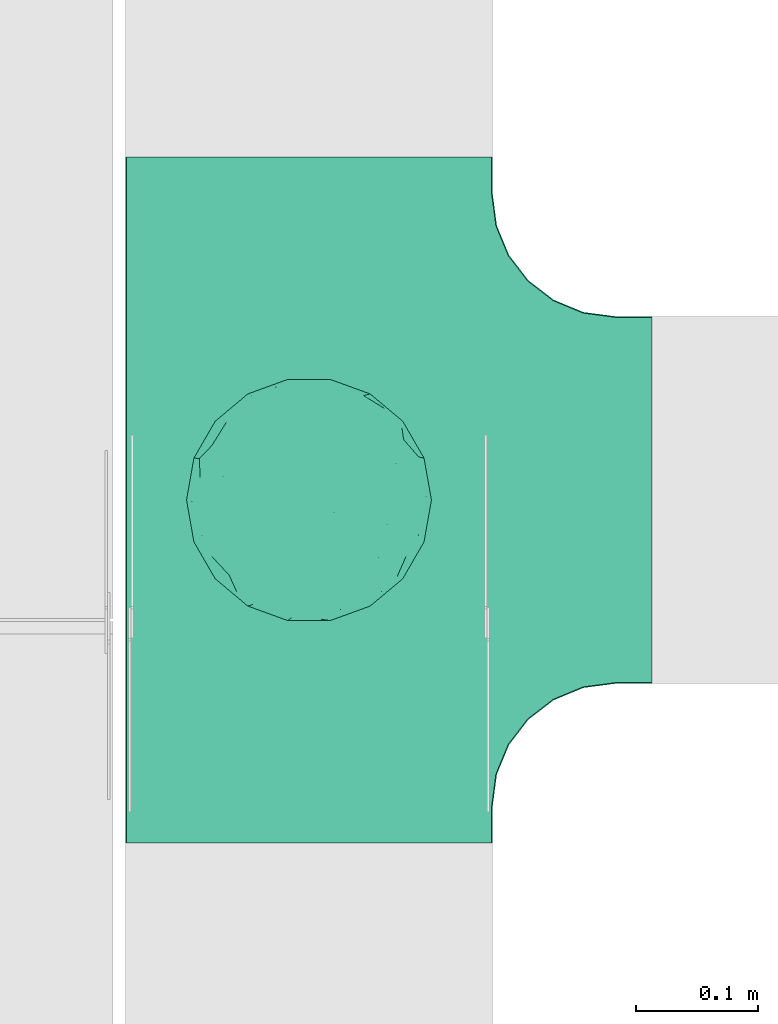
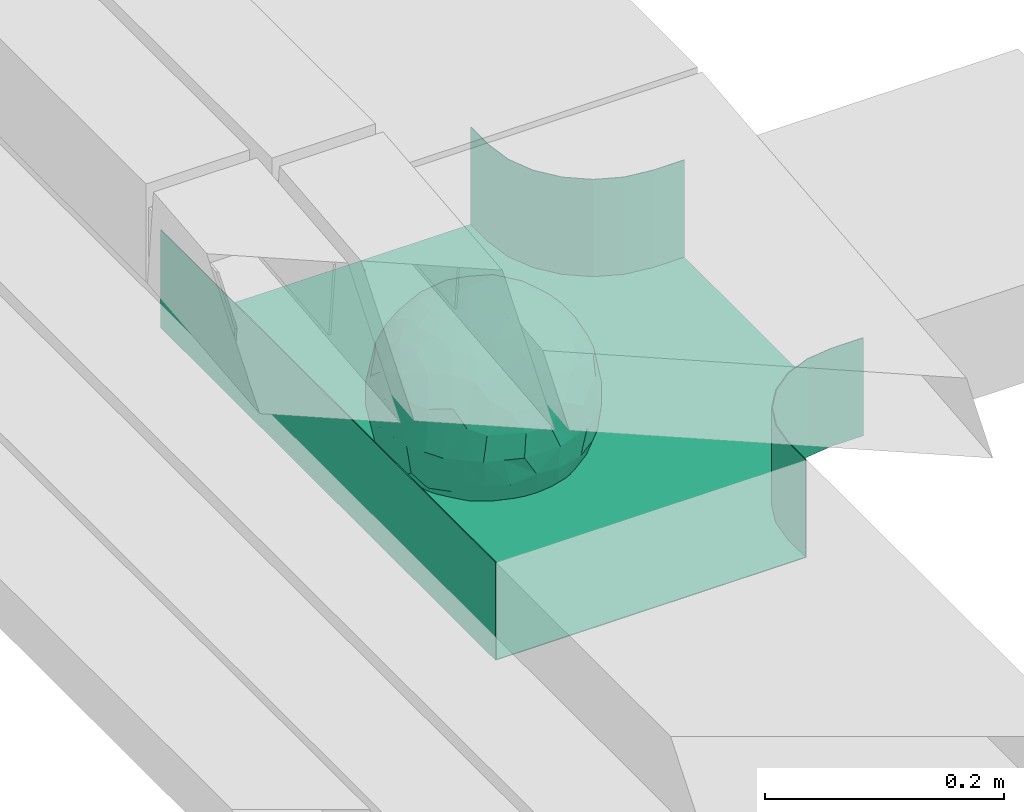
# One storey, part 7 of 33: 1 flow fitting.
"""IFC2X3 building model written with IfcOpenShell, lengths in millimetres."""

from ifc_helpers import new_model, entity, si_unit, converted_unit, derived_unit, direction, frame, origin, place, context, subcontext, project, spatial, faceted_brep, source, transform, mapped, material, material_list, type_object, type_shapes, element, save


model = new_model("IFC2X3")

# Units and contexts
model_context = context("Model", 3, precision=0.01, world=origin(), true_north=direction((6.12303176911189e-17, 1.0)))
body_context = subcontext(model_context, "Body", "Model", "MODEL_VIEW")
ifc_project = project(units=[si_unit("LENGTHUNIT", "METRE", prefix="MILLI"), si_unit("AREAUNIT", "SQUARE_METRE"), si_unit("VOLUMEUNIT", "CUBIC_METRE"), converted_unit("PLANEANGLEUNIT", "DEGREE", entity("IfcRatioMeasure", 0.0174532925199433), si_unit("PLANEANGLEUNIT", "RADIAN"), dimensions=[0, 0, 0, 0, 0, 0, 0]), si_unit("MASSUNIT", "GRAM", prefix="KILO"), derived_unit("MASSDENSITYUNIT", [(si_unit("MASSUNIT", "GRAM", prefix="KILO"), 1), (si_unit("LENGTHUNIT", "METRE"), -3)]), derived_unit("MOMENTOFINERTIAUNIT", [(si_unit("LENGTHUNIT", "METRE"), 4)]), si_unit("TIMEUNIT", "SECOND"), si_unit("FREQUENCYUNIT", "HERTZ"), si_unit("THERMODYNAMICTEMPERATUREUNIT", "DEGREE_CELSIUS"), derived_unit("THERMALTRANSMITTANCEUNIT", [(si_unit("MASSUNIT", "GRAM", prefix="KILO"), 1), (si_unit("THERMODYNAMICTEMPERATUREUNIT", "KELVIN"), -1), (si_unit("TIMEUNIT", "SECOND"), -3)]), derived_unit("VOLUMETRICFLOWRATEUNIT", [(si_unit("LENGTHUNIT", "METRE"), 3), (si_unit("TIMEUNIT", "SECOND"), -1)]), derived_unit("MASSFLOWRATEUNIT", [(si_unit("MASSUNIT", "GRAM", prefix="KILO"), 1), (si_unit("TIMEUNIT", "SECOND"), -1)]), derived_unit("ROTATIONALFREQUENCYUNIT", [(si_unit("TIMEUNIT", "SECOND"), -1)]), si_unit("ELECTRICCURRENTUNIT", "AMPERE"), si_unit("ELECTRICVOLTAGEUNIT", "VOLT"), si_unit("POWERUNIT", "WATT"), si_unit("FORCEUNIT", "NEWTON", prefix="KILO"), si_unit("ILLUMINANCEUNIT", "LUX"), si_unit("LUMINOUSFLUXUNIT", "LUMEN"), si_unit("LUMINOUSINTENSITYUNIT", "CANDELA"), derived_unit("USERDEFINED", [(si_unit("MASSUNIT", "GRAM", prefix="KILO"), -1), (si_unit("LENGTHUNIT", "METRE"), -2), (si_unit("TIMEUNIT", "SECOND"), 3), (si_unit("LUMINOUSFLUXUNIT", "LUMEN"), 1)]), derived_unit("LINEARVELOCITYUNIT", [(si_unit("LENGTHUNIT", "METRE"), 1), (si_unit("TIMEUNIT", "SECOND"), -1)]), si_unit("PRESSUREUNIT", "PASCAL"), derived_unit("USERDEFINED", [(si_unit("LENGTHUNIT", "METRE"), -2), (si_unit("MASSUNIT", "GRAM", prefix="KILO"), 1), (si_unit("TIMEUNIT", "SECOND"), -2)]), derived_unit("LINEARFORCEUNIT", [(si_unit("MASSUNIT", "GRAM", prefix="KILO"), 1), (si_unit("LENGTHUNIT", "METRE"), 1), (si_unit("TIMEUNIT", "SECOND"), -2), (si_unit("LENGTHUNIT", "METRE"), -1)]), derived_unit("PLANARFORCEUNIT", [(si_unit("MASSUNIT", "GRAM", prefix="KILO"), 1), (si_unit("LENGTHUNIT", "METRE"), 1), (si_unit("TIMEUNIT", "SECOND"), -2), (si_unit("LENGTHUNIT", "METRE"), -2)])], contexts=[model_context])

# Site, building, storey
site_placement = place(None, frame((0.0, -0.00077364408347762, 0.0)))
site = spatial("IfcSite", under=ifc_project, at=site_placement, CompositionType="ELEMENT")
building_placement = place(site_placement, origin())
building = spatial("IfcBuilding", under=site, at=building_placement, CompositionType="ELEMENT")
storey_placement = place(building_placement, frame((0.0, 0.0, 8100.0)))
storey = spatial("IfcBuildingStorey", under=building, at=storey_placement, CompositionType="ELEMENT", Elevation=8100.0)

# Flow fitting
ifc_material_1 = material()
ifc_material_2 = material()
ifc_material_list = material_list([ifc_material_1, ifc_material_2])
cable_carrier_fitting_type = type_object("IfcCableCarrierFittingType", PredefinedType="NOTDEFINED", material=ifc_material_1)
shared_shape = source(origin(), body_context, "Body", "Brep", [
    faceted_brep([(76.4840203203325, -37.7983376575012, -52.1678090968869), (89.2874188526836, -26.168482477916, -36.6465190629256), (85.270060821053, -46.6341564571094, -23.5429857730317), (-17.2892276551183, -34.784102350051, -92.1474298653505), (3.07548730030541e-06, -44.1611501073546, -89.7206376548624), (-24.6383925717335, -51.5777741549417, -82.0529269721827), (76.3287929967882, -15.079107031813, -62.8214604317408), (55.5757044674811, -29.5498647779489, -77.7055118028838), (-17.1010071662778, 96.9846310392869, 0.0), (-18.6742130440203, 88.8859886245005, -41.8396318510259), (-33.8953581705111, 89.5312614551001, -28.9008289976074), (-45.4623263334585, -10.4806178463803, -88.4496101399357), (-19.8193717281607, 5.04030654129894, -97.8866069197874), (-23.6628375063711, -16.1276312747485, -95.8121580521565), (92.5416578398381, 33.6824088833379, 0.0), (85.2767902974019, 45.7715256118899, -25.1562413673598), (86.6025403784496, 50.0, 0.0), (49.240387650616, -85.2868531952529, 0.0), (62.2001900548409, -72.1916708642314, -30.3232421580155), (64.2787609686595, -76.6044443119063, 0.0), (97.1714774391015, -8.71557429474411, -21.948638614181), (90.7615649771405, 0.0, -41.9802134689751), (96.1413151932242, 14.3969945426304, -23.4429959914917), (98.4807753012265, 17.3648177666844, 0.0), (98.4807753012265, 0.0, 0.0), (79.0119763428423, 8.47783312434252, -60.7061276965826), (76.4840203202329, 37.7983376578076, -52.1678090967986), (87.696722672108, 23.4364088603614, -41.9525871943713), (29.163429357778, -37.5977865113054, -87.9539699930814), (20.3014061890807, -63.7692165377112, -74.3057193553274), (-69.6223300212076, 53.192794202726, -48.2001847229044), (-47.2059268691477, 56.745965379315, -67.4647751170325), (-61.603837577254, 43.4748411443104, -65.6879394046569), (29.4497539748763, 71.3200718492295, -63.6094280923684), (47.2059306757939, 56.745965229418, -67.4647725795649), (30.0444734578003, 49.6507498561999, -81.4379067348793), (-49.6683382574198, -77.0947032728586, -39.8680687018642), (-34.202014332561, -93.9692620785994, 0.0), (-49.2403876506046, -85.2868531952529, 0.0), (61.3953921577507, 65.1440685107005, -44.5741647108287), (74.6816445462022, 59.1436972034819, -30.4084700203242), (61.9457748290475, 44.5417169664605, -64.6433015130544), (28.7737714324073, -89.42049207415, -34.2935223442239), (34.2020143325724, -93.9692620785994, 0.0), (25.6515107494307, -95.4769465589517, 0.0), (17.101007166289, -96.9846310393039, 0.0), (-64.2787609686481, -76.6044443119063, 0.0), (-75.4406506735431, -63.3022221559575, 0.0), (-74.7500995498228, -61.5460620722206, -24.9900952517949), (7.49675578587143, -83.6888268592038, -54.2215723823823), (36.4863653716413, -70.367842623822, -60.9681217230515), (-76.4840178500364, -37.798342255337, -52.1678093872333), (-87.0716088907139, -22.4880335791362, -43.7358350889169), (-79.0617266871127, -6.53517927425345, -60.8813173732629), (63.5329768828015, 0.0, -77.2240949989638), (-63.5329752663337, -4.28405924068898e-09, -77.2240963288374), (-81.9271917640341, 16.0413321025015, -55.0509846781547), (-98.4807753012151, -17.3648177667017, 0.0), (-95.569577544237, -17.0482102820805, -23.9961324840668), (-92.5416578398266, -33.6824088833551, 0.0), (65.8639795091221, 23.4057144961932, -71.5129969456177), (-19.2962502251216, 70.2650181304482, -68.487093341555), (-44.3250940555787, 79.4239687498613, -41.5586239543935), (-76.4840178487499, 37.7983422512769, -52.1678093920491), (-45.0467119602772, 37.358552492076, -81.0871894768975), (-67.1951546795767, 22.414876352536, -70.586007860525), (45.8905780821677, 15.5420810523434, -87.478560572553), (-67.1382383390432, -22.457587679949, -70.6265793333204), (-97.6852110527561, 5.09344694659685, -20.7763408659754), (-90.761561927752, 1.63062869873443e-09, -41.9802200617526), (-92.5416578398267, 33.6824088833379, 0.0), (-92.1520232806737, 27.1973992873941, -27.7183346772189), (28.8657365411401, 87.5169428696254, -38.8272322563751), (7.49675578553467, 83.6888268595355, -54.2215723818906), (1.22951801366171, 95.7251008343745, -28.8997120349128), (3.5162183498022, -95.8354910731824, -28.3406926393789), (-8.55050358313599, -98.4923155196562, 0.0), (-12.2828353145794, -96.1465810571431, -24.5960750457924), (75.4406506735547, 63.3022221559403, 0.0), (64.2787609686598, 76.6044443118892, 0.0), (75.4406506735545, -63.3022221559575, 0.0), (86.6025403784495, -50.0, 0.0), (-75.4406506735433, 63.3022221559403, 0.0), (-84.8930621241031, 46.8074333743426, -24.5404193953063), (-86.6025403784383, 50.0, 0.0), (-65.6229030223494, -61.3889655017833, -43.8751582736728), (-47.2059268729136, -56.7459653834318, -67.4647751109489), (-85.2400449211107, -44.6766589600176, -27.1685642980393), (46.0205786918846, 37.1654843094529, -80.6277440643515), (-63.1788213480048, 67.6783588085196, -37.7898965605855), (-7.15444733827542, -67.6177156734158, -73.3257008857939), (31.5424765006817, -5.30265693589207, -94.7467888934671), (9.84735642755859, -20.4964224402077, -97.3803175109847), (1.0083019663368e-06, 13.3030981775211, -99.111187960177), (49.3513473168359, -11.1781440260195, -86.252499176233), (92.541657839838, -33.6824088833551, 0.0), (98.4807753012265, -17.3648177667017, 0.0), (49.2403876506163, 85.2868531952358, 0.0), (46.4041236261553, 79.1080859305986, -39.8568444672194), (34.2020143325727, 93.9692620785823, 0.0), (-53.1130236264114, 15.1205787052499, -83.3689079985849), (64.5322070769988, -54.17210261472, -53.8607236125959), (47.2059306758545, -56.745965228813, -67.4647725800455), (22.8875622085795, 27.5743091168824, -93.3585399032859), (74.6816445462803, -59.1436972033529, -30.4084700204161), (46.4041236262572, -79.108085930386, -39.8568444675565), (-15.7383008676665, 23.1933977335444, -95.9915214348144), (2.80963889519618, 33.9846447662373, -94.0061160211894), (9.20690877800443, 52.3900236205866, -84.6789126984153), (9.72607601259755, 69.7500364970203, -70.995322761851), (17.1010071662892, 96.9846310392869, 0.0), (-5.62154210059744, -90.1648531765776, -42.8800363346189), (0.0, -100.0, 0.0), (-25.1293295965289, -93.3686387308287, -25.5110582999201), (-25.949186528859, -84.8833009001169, -46.0593632912046), (-17.1010071662777, -96.9846310393039, 0.0), (-10.2354907319271, -80.7824512711375, -58.0467940208873), (-31.237630661844, -69.7640997378305, -64.4762035048911), (-42.1850269133029, -33.6354441712551, -84.1966768924114), (-35.781529361024, 18.547890266457, -91.5186206367184), (-61.619736792185, -43.523827571712, -65.6405703141646), (-17.3443611696694, 40.8888850191612, -89.595045719636), (-29.1001411816516, 55.690814260002, -77.7927695243168), (-10.6569193640809, 57.0342754657797, -81.4464332660353), (-59.774866149928, -75.5723898452015, -26.7540514659609), (-86.6025403784381, -50.0, 0.0), (-98.4807753012151, 0.0, 0.0), (-98.4807753012152, 17.3648177666844, 0.0), (-74.7670053246598, 60.7049605869996, -26.9221595513964), (-64.2787609686484, 76.6044443118892, 0.0), (-49.2403876506049, 85.2868531952358, 0.0), (-34.2020143325614, 93.9692620785823, 0.0), (0.0, 100.0, 0.0), (-76.484019526794, -37.798337198235, 52.1678105930665), (-89.2874185112873, -26.1684825046027, 36.6465198756512), (-85.2700607126513, -46.6341564521743, 23.5429861753997), (17.2892307880813, -34.7841011602588, 92.1474297266695), (-3.38734512270379e-07, -44.1611496359296, 89.720637886916), (24.6383956411536, -51.5777728113463, 82.0529268951053), (-76.3287917934888, -15.0791068021182, 62.8214619488982), (-55.5757026100472, -29.549864599369, 77.7055131992549), (18.6742091034424, 88.885990914275, 41.8396287453374), (33.8953586129312, 89.5312597468659, 28.9008337706599), (17.3443607633453, 40.8888810970192, 89.5950475882768), (15.7383028761951, 23.1933956687767, 95.9915216044101), (35.7815318404767, 18.5478901047313, 91.5186197001092), (-85.2767901734143, 45.7715256234335, 25.1562417666364), (-62.2001897574699, -72.1916707653145, 30.3232430034808), (-97.1714773187454, -8.71557427953189, 21.9486391530291), (-96.141315013212, 14.3969947624817, 23.4429965946852), (-79.0119753418501, 8.47783306286876, 60.7061290080075), (-76.4840195267832, 37.7983371982528, 52.1678105930571), (-87.6967222099395, 23.4364087722604, 41.9525882096856), (-29.163427099677, -37.5977868949179, 87.9539705778413), (-20.301404034393, -63.7692173365967, 74.305719258427), (69.6223307049661, 53.192787114506, 48.2001915577083), (47.2059293170501, 56.7459646829409, 67.4647739899622), (61.6038389573326, 43.4748357207471, 65.6879416999347), (-61.3953919237905, 65.1440676388516, 44.5741663072653), (49.2659552585237, -77.3488009806731, 39.8751631886295), (-74.681644350378, 59.1436969740875, 30.4084709474116), (-61.9457736264423, 44.5417164806275, 64.643303000237), (-7.49675472945651, -83.6888265867081, 54.2215729490431), (-36.486364416374, -70.367842442625, 60.968122503872), (-28.7737710558201, -89.4204919730988, 34.2935229236939), (74.7446466999101, -61.6521905333982, 24.7435889098862), (3.00446277704405, -95.5180690083503, 29.4494770130044), (-13.4675721353261, -92.748406770264, 34.876317786707), (76.4840204055964, -37.7983390347103, 52.167807974034), (87.0716107179514, -22.4880293497667, 43.7358336258448), (79.0617298359488, -6.53517466347878, 60.8813137790831), (-63.5329751791014, 0.0, 77.2240964006191), (63.5329772594296, 0.0, 77.2240946891232), (81.9271971902465, 16.0413321407425, 55.050976591722), (95.5695783977716, -17.0482115223089, 23.9961282036192), (-65.8639781491499, 23.405714160557, 71.5129983080176), (19.2962569358552, 70.2650237882598, 68.4870856461333), (44.3251010195622, 79.4239674638786, 41.5586189845396), (76.4840204055789, 37.7983390346199, 52.1678079741129), (45.0467113579588, 37.35855313631, 81.0871895147151), (67.1951616703757, 22.4148716107117, 70.5860027113649), (-45.8905758090763, 15.5420810346383, 87.4785617681537), (67.1382437930653, -22.4575840893256, 70.6265752904385), (97.6852138116852, 5.09344112492882, 20.7763293214556), (90.7615650780775, 0.0, 41.9802132507632), (92.1520274335419, 27.1973943799444, 27.7183256859159), (-28.8657360653296, 87.5169427229152, 38.8272329408042), (-7.49675472951015, 83.6888265867653, 54.2215729489213), (-1.22952463606755, 95.725101063195, 28.8997109952541), (7.15445060231028, -67.6177152767913, 73.3257009330848), (30.0445391888188, -71.0236195697132, 63.6629494144802), (-90.7615645164956, 0.0, 41.9802144648834), (84.8930644946618, 46.8074299509675, 24.5404177244603), (65.657396767693, -61.8519680594647, 43.1675838664051), (47.2059293174508, -56.7459646832734, 67.4647739894163), (85.240045822543, -44.6766582374337, 27.1685626581248), (-30.0444712047215, 49.6507502843406, 81.4379073050796), (-47.2059295896367, 56.7459650911412, 67.4647734558766), (-46.0205764805425, 37.1654842487523, 80.6277453545262), (63.1788267861392, 67.6783521071165, 37.7898994705241), (-31.542473908998, -5.30265693887445, 94.7467897561175), (-9.84735391303847, -20.4964227184575, 97.3803177067078), (1.34873765353802e-06, 13.3030991109957, 99.1111878348972), (-49.3513452292634, -11.1781439777262, 86.2525003769525), (-46.4041232356316, 79.1080858261746, 39.8568451291574), (-29.4497536788485, 71.3200715314942, 63.609428585683), (24.3100719261245, -93.7923353358836, 24.7390023078953), (-64.5322063997089, -54.1721023527289, 53.8607246875848), (-47.2059295895764, -56.7459650910276, 67.4647734560286), (-22.8875602129064, 27.5743087068143, 93.3585405136699), (-46.4041232356225, -79.1080858261415, 39.8568451292672), (-74.6816443503883, -59.1436969740864, 30.408470947421), (19.8193741532226, 5.04030693924503, 97.8866064083047), (-2.80963679644177, 33.9846454726014, 94.0061158285697), (-9.20690598859987, 52.3900245858364, 84.6789124045226), (-9.72607582248976, 69.7500367089908, 70.9953225796557), (9.6507963138497, -80.5368358032807, 58.4865814465705), (23.4705761898964, -86.311306248728, 44.7156624344864), (35.1118074315221, -89.6215726748419, 27.113367370765), (42.1850318693192, -33.6354421467953, 84.1966752180655), (23.6628407100174, -16.1276300406404, 95.8121574686978), (45.4623290073054, -10.4806171517165, 88.4496088479348), (61.6197386049218, -43.5238234805734, 65.6405713251752), (29.1001407425045, 55.6908137196801, 77.7927700754181), (10.6569061579526, 57.0342796833114, 81.4464320406166), (59.3537179746501, -75.8188405832575, 26.9933246414488), (74.7670061544982, 60.7049632941286, 26.9221511427291), (53.1130277137063, 15.1205817594398, 83.3689048407183)], [[[0, 1, 2]], [[3, 4, 5]], [[6, 0, 7]], [[8, 9, 10]], [[11, 12, 13]], [[14, 15, 16]], [[17, 18, 19]], [[20, 21, 22]], [[22, 23, 24]], [[25, 26, 27]], [[4, 28, 29]], [[30, 31, 32]], [[33, 34, 35]], [[36, 37, 38]], [[39, 40, 41]], [[42, 43, 44, 45]], [[46, 47, 48]], [[49, 50, 42]], [[51, 52, 53]], [[54, 25, 6]], [[55, 53, 56]], [[57, 58, 59]], [[26, 25, 60]], [[61, 31, 62]], [[32, 63, 30]], [[64, 65, 32]], [[54, 66, 60]], [[53, 67, 51]], [[58, 68, 69]], [[68, 70, 71]], [[72, 73, 74]], [[75, 76, 77]], [[6, 7, 54]], [[24, 20, 22]], [[78, 40, 79]], [[15, 26, 40]], [[1, 21, 20]], [[80, 2, 81]], [[63, 56, 71]], [[82, 83, 84]], [[36, 85, 86]], [[87, 58, 52]], [[35, 34, 88]], [[62, 31, 89]], [[42, 75, 49]], [[4, 29, 90]], [[91, 92, 93]], [[7, 94, 54]], [[6, 1, 0]], [[95, 81, 2]], [[24, 96, 20]], [[1, 20, 95]], [[1, 95, 2]], [[27, 22, 21]], [[15, 14, 22]], [[25, 27, 21]], [[15, 78, 16]], [[41, 40, 26]], [[40, 78, 15]], [[39, 97, 79]], [[97, 98, 99]], [[40, 39, 79]], [[33, 73, 72]], [[21, 1, 6]], [[25, 54, 60]], [[64, 100, 65]], [[26, 15, 27]], [[6, 25, 21]], [[0, 101, 7]], [[102, 28, 7]], [[92, 91, 28]], [[94, 28, 91]], [[88, 34, 41]], [[54, 94, 66]], [[41, 26, 60]], [[103, 91, 93]], [[88, 41, 60]], [[20, 96, 95]], [[101, 18, 102]], [[104, 80, 19]], [[101, 0, 104]], [[18, 105, 102]], [[43, 42, 105]], [[17, 43, 105]], [[29, 28, 102]], [[28, 4, 92]], [[105, 50, 102]], [[90, 29, 49]], [[88, 60, 66]], [[41, 34, 39]], [[34, 98, 39]], [[97, 39, 98]], [[103, 66, 91]], [[88, 66, 103]], [[12, 106, 93]], [[33, 98, 34]], [[107, 103, 93]], [[35, 103, 108]], [[103, 35, 88]], [[33, 109, 73]], [[109, 35, 108]], [[110, 72, 74]], [[72, 110, 99]], [[98, 33, 72]], [[99, 98, 72]], [[80, 104, 2]], [[0, 2, 104]], [[101, 104, 18]], [[7, 101, 102]], [[19, 18, 104]], [[105, 18, 17]], [[77, 111, 75]], [[75, 45, 112]], [[113, 114, 111]], [[115, 77, 76]], [[36, 114, 37]], [[90, 5, 4]], [[75, 42, 45]], [[50, 49, 29]], [[49, 116, 90]], [[5, 117, 86]], [[90, 116, 117]], [[118, 13, 3]], [[118, 5, 86]], [[11, 119, 12]], [[67, 120, 51]], [[11, 13, 118]], [[65, 55, 56]], [[121, 122, 123]], [[90, 117, 5]], [[51, 120, 85]], [[117, 36, 86]], [[36, 117, 114]], [[46, 48, 124]], [[38, 124, 36]], [[85, 124, 48]], [[87, 125, 59]], [[125, 87, 47]], [[48, 51, 85]], [[68, 57, 126, 127]], [[59, 58, 87]], [[58, 69, 52]], [[53, 52, 69]], [[87, 52, 51]], [[56, 53, 69]], [[53, 55, 67]], [[71, 56, 69]], [[56, 63, 65]], [[71, 69, 68]], [[128, 129, 89]], [[11, 67, 55]], [[120, 118, 86]], [[32, 65, 63]], [[100, 55, 65]], [[118, 120, 67]], [[85, 120, 86]], [[129, 128, 82]], [[64, 32, 31]], [[62, 130, 131]], [[130, 62, 89]], [[9, 73, 61]], [[10, 62, 131]], [[109, 61, 73]], [[73, 9, 74]], [[64, 121, 119]], [[122, 61, 123]], [[64, 119, 100]], [[64, 31, 122]], [[107, 108, 103]], [[47, 87, 48]], [[51, 48, 87]], [[57, 68, 58]], [[64, 122, 121]], [[89, 129, 130]], [[67, 11, 118]], [[11, 55, 100]], [[82, 128, 83]], [[30, 128, 89]], [[83, 63, 71]], [[63, 83, 128]], [[84, 83, 71]], [[10, 61, 62]], [[74, 8, 132]], [[8, 74, 9]], [[110, 74, 132]], [[3, 92, 4]], [[92, 13, 12]], [[22, 27, 15]], [[14, 23, 22]], [[11, 100, 119]], [[128, 30, 63]], [[31, 30, 89]], [[28, 94, 7]], [[66, 94, 91]], [[42, 50, 105]], [[29, 102, 50]], [[106, 107, 93]], [[123, 107, 121]], [[35, 109, 33]], [[109, 108, 123]], [[75, 112, 76]], [[113, 77, 115]], [[114, 116, 111]], [[115, 37, 113]], [[37, 114, 113]], [[49, 75, 111]], [[117, 116, 114]], [[111, 77, 113]], [[49, 111, 116]], [[118, 3, 5]], [[92, 3, 13]], [[106, 119, 121]], [[92, 12, 93]], [[119, 106, 12]], [[107, 106, 121]], [[46, 124, 38]], [[85, 36, 124]], [[70, 68, 127]], [[70, 84, 71]], [[31, 61, 122]], [[109, 123, 61]], [[107, 123, 108]], [[8, 10, 131]], [[61, 10, 9]], [[133, 134, 135]], [[136, 137, 138]], [[139, 133, 140]], [[110, 141, 142]], [[143, 144, 145]], [[70, 146, 84]], [[38, 147, 46]], [[126, 57, 148]], [[149, 127, 126]], [[150, 151, 152]], [[137, 153, 154]], [[155, 156, 157]], [[130, 129, 158]], [[159, 43, 17]], [[158, 160, 161]], [[162, 163, 164]], [[19, 80, 165]], [[166, 167, 115]], [[168, 169, 170]], [[171, 150, 139]], [[172, 170, 173]], [[96, 174, 95]], [[151, 150, 175]], [[176, 156, 177]], [[157, 178, 155]], [[179, 180, 157]], [[171, 181, 175]], [[170, 182, 168]], [[174, 183, 184]], [[185, 23, 14, 16]], [[186, 187, 188]], [[138, 189, 190]], [[139, 140, 171]], [[126, 148, 149]], [[82, 160, 129]], [[146, 151, 160]], [[134, 191, 148]], [[47, 135, 125]], [[178, 173, 185]], [[78, 192, 16]], [[159, 193, 194]], [[195, 174, 169]], [[196, 197, 198]], [[177, 156, 199]], [[166, 112, 45]], [[154, 189, 137]], [[200, 201, 202]], [[140, 203, 171]], [[191, 149, 148]], [[59, 125, 135]], [[133, 139, 134]], [[134, 148, 59]], [[134, 59, 135]], [[152, 149, 191]], [[146, 70, 149]], [[150, 152, 191]], [[146, 82, 84]], [[161, 160, 151]], [[160, 82, 146]], [[204, 131, 130]], [[186, 205, 187]], [[160, 158, 129]], [[197, 196, 205]], [[191, 134, 139]], [[150, 171, 175]], [[45, 206, 166]], [[151, 146, 152]], [[139, 150, 191]], [[133, 207, 140]], [[208, 153, 140]], [[201, 200, 153]], [[203, 153, 200]], [[198, 197, 161]], [[171, 203, 181]], [[161, 151, 175]], [[209, 200, 202]], [[198, 161, 175]], [[148, 57, 59]], [[38, 37, 210]], [[211, 47, 46]], [[207, 133, 211]], [[147, 210, 208]], [[210, 37, 164]], [[208, 207, 147]], [[154, 153, 208]], [[153, 137, 201]], [[210, 163, 208]], [[189, 154, 162]], [[198, 175, 181]], [[161, 197, 158]], [[197, 204, 158]], [[130, 158, 204]], [[209, 181, 200]], [[198, 181, 209]], [[212, 144, 202]], [[205, 204, 197]], [[213, 209, 202]], [[196, 209, 214]], [[209, 196, 198]], [[205, 215, 187]], [[215, 196, 214]], [[8, 186, 188]], [[186, 8, 131]], [[204, 205, 186]], [[131, 204, 186]], [[47, 211, 135]], [[133, 135, 211]], [[207, 211, 147]], [[140, 207, 208]], [[46, 147, 211]], [[210, 147, 38]], [[166, 115, 76, 112]], [[115, 164, 37]], [[163, 162, 154]], [[216, 166, 217]], [[138, 137, 189]], [[162, 216, 189]], [[218, 44, 43]], [[44, 218, 206]], [[189, 216, 190]], [[219, 220, 136]], [[219, 138, 194]], [[221, 145, 212]], [[182, 222, 168]], [[221, 220, 219]], [[180, 172, 173]], [[143, 223, 224]], [[168, 222, 193]], [[194, 138, 190]], [[190, 159, 194]], [[190, 217, 218]], [[19, 165, 225]], [[17, 225, 159]], [[193, 225, 165]], [[195, 81, 95]], [[81, 195, 80]], [[165, 168, 193]], [[183, 96, 24, 23]], [[95, 174, 195]], [[174, 184, 169]], [[170, 169, 184]], [[195, 169, 168]], [[173, 170, 184]], [[170, 172, 182]], [[185, 173, 184]], [[173, 178, 180]], [[185, 184, 183]], [[226, 79, 199]], [[221, 182, 172]], [[222, 219, 194]], [[157, 180, 178]], [[227, 172, 180]], [[219, 222, 182]], [[193, 222, 194]], [[79, 226, 78]], [[179, 157, 156]], [[177, 97, 99]], [[97, 177, 199]], [[141, 187, 176]], [[142, 177, 99]], [[215, 176, 187]], [[187, 141, 188]], [[179, 143, 145]], [[223, 176, 224]], [[179, 145, 227]], [[179, 156, 223]], [[213, 214, 209]], [[96, 183, 174]], [[185, 183, 23]], [[80, 195, 165]], [[168, 165, 195]], [[199, 79, 97]], [[182, 221, 219]], [[221, 172, 227]], [[78, 226, 192]], [[155, 226, 199]], [[192, 178, 185]], [[178, 192, 226]], [[16, 192, 185]], [[142, 176, 177]], [[188, 110, 132]], [[110, 188, 141]], [[8, 188, 132]], [[136, 201, 137]], [[201, 220, 212]], [[149, 152, 146]], [[70, 127, 149]], [[167, 162, 164]], [[179, 227, 180]], [[221, 227, 145]], [[226, 155, 178]], [[156, 155, 199]], [[153, 203, 140]], [[181, 203, 200]], [[164, 163, 210]], [[154, 208, 163]], [[144, 213, 202]], [[224, 213, 143]], [[196, 215, 205]], [[215, 214, 224]], [[166, 216, 162]], [[190, 216, 217]], [[218, 217, 206]], [[43, 159, 218]], [[190, 218, 159]], [[166, 206, 217]], [[44, 206, 45]], [[219, 136, 138]], [[201, 136, 220]], [[201, 212, 202]], [[221, 212, 220]], [[145, 144, 212]], [[213, 144, 143]], [[19, 225, 17]], [[193, 159, 225]], [[179, 223, 143]], [[156, 176, 223]], [[215, 224, 176]], [[213, 224, 214]], [[110, 142, 99]], [[176, 142, 141]], [[115, 167, 164]], [[166, 162, 167]]]),
    faceted_brep([(-153.407417371086, -224.118095489753, 50.0), (-150.0, -250.0, 50.0), (-150.0, -280.0, 50.0), (-149.199999999993, -280.0, 50.0), (-149.199999999993, -250.0, 50.0), (-152.634676710055, -223.911040253671, 50.0), (-162.704639298522, -199.600000000004, 50.0), (-178.723636456391, -178.7236364564, 50.0), (-199.599999999996, -162.704639298532, 50.0), (-223.911040253663, -152.634676710066, 50.0), (-250.0, -149.200000000004, 50.0), (-280.0, -149.200000000004, 50.0), (-280.0, -150.0, 50.0), (-250.0, -150.0, 50.0), (-224.118095489745, -153.407417371099, 50.0), (-200.0, -163.397459621561, 50.0), (-179.28932188134, -179.289321881349, 50.0), (-163.39745962155, -200.0, 50.0), (280.0, -150.0, 50.0), (280.0, -149.200000000004, 50.0), (250.0, -149.200000000007, 50.0), (223.911040253719, -152.634676710068, 50.0), (199.600000000048, -162.704639298534, 50.0), (178.723636456437, -178.7236364564, 50.0), (162.70463929856, -199.600000000004, 50.0), (152.634676710083, -223.91104025367, 50.0), (149.200000000009, -250.0, 50.0), (149.200000000007, -280.0, 50.0), (150.0, -280.0, 50.0), (150.0, -250.0, 50.0), (153.407417371116, -224.118095489752, 50.0), (163.39745962159, -200.0, 50.0), (179.289321881388, -179.289321881351, 50.0), (200.0, -163.397459621564, 50.0), (224.118095489802, -153.407417371102, 50.0), (250.0, -150.0, 50.0), (280.0, 149.199999999995, 50.0), (280.0, 150.0, 50.0), (-280.0, 150.0, 50.0), (-280.0, 149.199999999995, 50.0), (-280.0, -150.0, -50.0), (-280.0, 150.0, -50.0), (280.0, 150.0, -50.0), (280.0, -150.0, -50.0), (250.0, -150.0, -50.0), (224.118095489802, -153.407417371102, -50.0), (200.0, -163.397459621564, -50.0), (179.289321881388, -179.289321881351, -50.0), (163.39745962159, -200.0, -50.0), (153.407417371116, -224.118095489752, -50.0), (150.0, -250.0, -50.0), (150.0, -280.0, -50.0), (-150.0, -280.0, -50.0), (-150.0, -250.0, -50.0), (-153.407417371086, -224.118095489753, -50.0), (-163.39745962155, -200.0, -50.0), (-179.28932188134, -179.289321881349, -50.0), (-200.0, -163.397459621561, -50.0), (-224.118095489745, -153.407417371099, -50.0), (-250.0, -150.0, -50.0), (-150.0, -250.0, -49.1999999999851), (149.200000000007, -280.0, -49.1999999999851), (-149.199999999993, -280.0, -49.1999999999851), (-149.199999999993, -250.0, -49.1999999999851), (-250.0, -149.200000000004, -49.1999999999851), (-280.0, -149.200000000004, -49.1999999999851), (280.0, -149.200000000004, -49.1999999999851), (250.0, -149.200000000004, -49.1999999999851), (-280.0, 149.199999999995, -49.1999999999851), (-250.0, -150.0, -49.1999999999851), (250.0, -150.0, -49.1999999999851), (280.0, 149.199999999995, -49.1999999999851), (149.200000000009, -250.0, -49.1999999999851), (150.0, -250.0, -49.1999999999851), (-223.911040253663, -152.634676710066, -49.1999999999851), (-199.599999999996, -162.704639298532, -49.1999999999851), (-178.723636456391, -178.7236364564, -49.1999999999851), (-162.704639298522, -199.600000000004, -49.1999999999851), (-152.634676710055, -223.911040253671, -49.1999999999851), (152.634676710083, -223.911040253671, -49.1999999999851), (162.70463929856, -199.600000000004, -49.1999999999851), (178.723636456436, -178.723636456401, -49.1999999999851), (199.600000000047, -162.704639298534, -49.1999999999851), (223.911040253719, -152.634676710069, -49.1999999999851)], [[[0, 1, 2, 3, 4, 5, 6, 7, 8, 9, 10, 11, 12, 13, 14, 15, 16, 17]], [[18, 19, 20, 21, 22, 23, 24, 25, 26, 27, 28, 29, 30, 31, 32, 33, 34, 35]], [[36, 37, 38, 39]], [[40, 41, 42, 43, 44, 45, 46, 47, 48, 49, 50, 51, 52, 53, 54, 55, 56, 57, 58, 59]], [[2, 1, 60, 53, 52]], [[3, 2, 52, 51, 28, 27, 61, 62]], [[4, 3, 62, 63]], [[11, 10, 64, 65]], [[20, 19, 66, 67]], [[39, 38, 41, 40, 12, 11, 65, 68]], [[13, 12, 40, 59, 69]], [[18, 35, 70, 44, 43]], [[19, 18, 43, 42, 37, 36, 71, 66]], [[27, 26, 72, 61]], [[29, 28, 51, 50, 73]], [[38, 37, 42, 41]], [[36, 39, 68, 71]], [[68, 65, 64, 74, 75, 76, 77, 78, 63, 62, 61, 72, 79, 80, 81, 82, 83, 67, 66, 71]], [[14, 13, 69, 59, 58]], [[15, 14, 58, 57]], [[57, 56, 16, 15]], [[17, 16, 56, 55]], [[0, 17, 55, 54]], [[1, 0, 54, 53, 60]], [[5, 78, 77, 6]], [[6, 77, 76, 7]], [[63, 78, 5, 4]], [[8, 75, 74, 9]], [[9, 74, 64, 10]], [[7, 76, 75, 8]], [[21, 83, 82, 22]], [[22, 82, 81, 23]], [[67, 83, 21, 20]], [[24, 80, 79, 25]], [[25, 79, 72, 26]], [[23, 81, 80, 24]], [[30, 29, 73, 50, 49]], [[31, 30, 49, 48]], [[32, 31, 48, 47]], [[34, 33, 46, 45]], [[34, 45, 44, 70, 35]], [[46, 33, 32, 47]]]),
])
type_shapes(cable_carrier_fitting_type, [shared_shape])
flow_fitting_placement = place(storey_placement, frame((18396.0523642072, 11376.2465616803, 2550.0), z_axis=(0.0, 0.0, 1.0), x_axis=(0.0, 1.0, 0.0)))
element("IfcFlowFitting", 1, at=flow_fitting_placement, inside=storey, type_object=cable_carrier_fitting_type, material=ifc_material_list, Name="470_DKC_S5_T", context=body_context, shape_type="MappedRepresentation", body=[
    mapped(shared_shape, transform((0.0, 0.0, 0.0), scale=1.0)),
])

save(model, "model.ifc")
